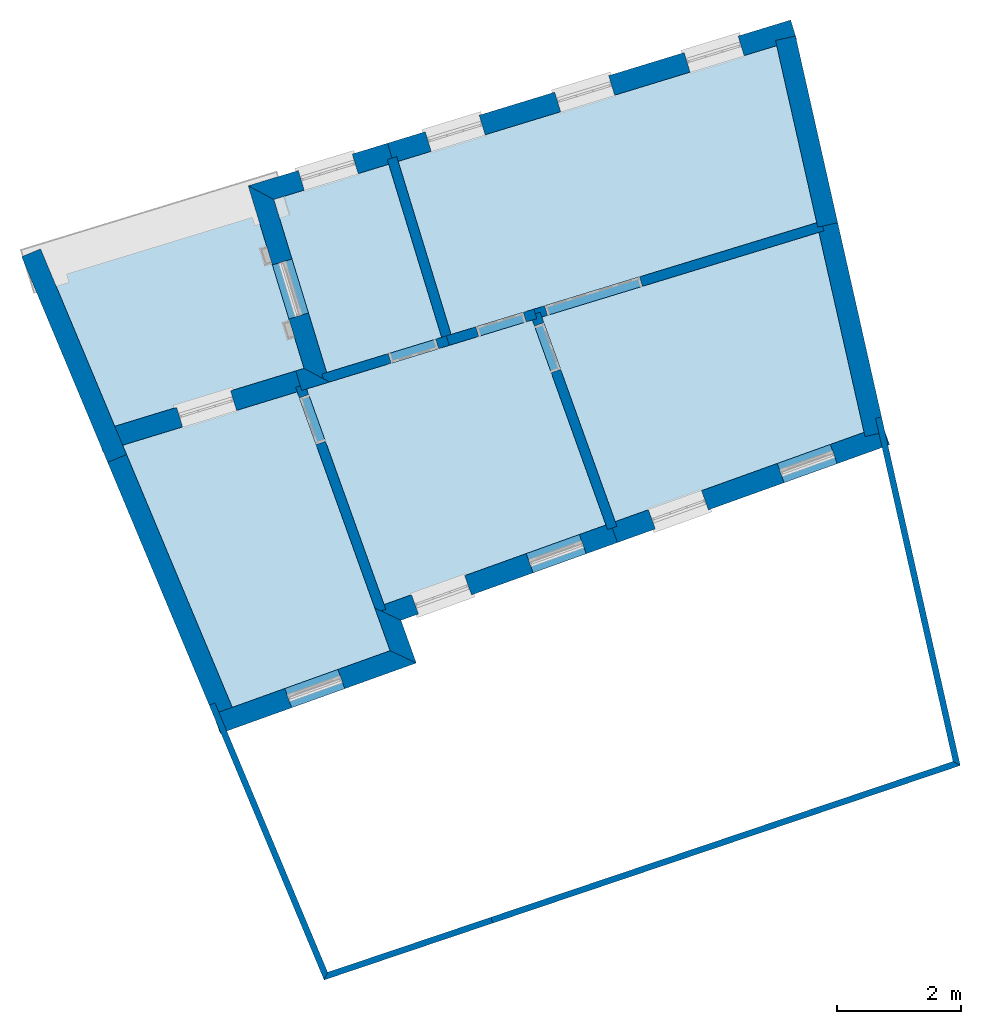
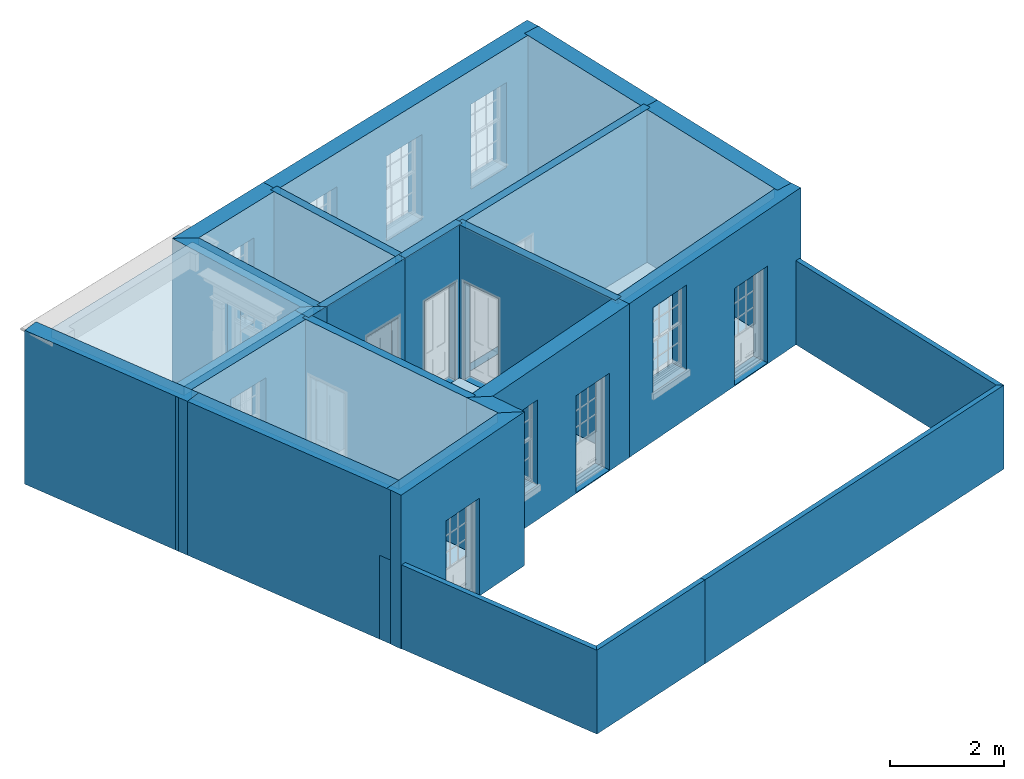
# One storey, part 1 of 10: 23 walls, 10 slabs, 16 openings.
"""IFC2X3 building model written with IfcOpenShell, lengths in metres."""

from ifc_helpers import new_model, si_unit, frame, origin, place, context, subcontext, project, spatial, polyline, outline, extrude, material, layer, layer_set, layer_usage, element, save


model = new_model("IFC2X3")

# Units and contexts
model_context = context("Model", 3, world=origin())
body_context = subcontext(model_context, "Body", "Model", "MODEL_VIEW")
ifc_project = project(units=[si_unit("PLANEANGLEUNIT", "RADIAN"), si_unit("MASSUNIT", "GRAM", prefix="KILO"), si_unit("FORCEUNIT", "NEWTON", prefix="KILO"), si_unit("LENGTHUNIT", "METRE")], contexts=[model_context])

# Site, building, storey
site_placement = place(None, origin())
site = spatial("IfcSite", under=ifc_project, at=site_placement, CompositionType="ELEMENT")
building_placement = place(None, origin())
building = spatial("IfcBuilding", under=site, at=building_placement, Name="Building plot-9", CompositionType="ELEMENT")
storey_placement = place(None, frame((0.0, 0.0, 1.0)))
storey = spatial("IfcBuildingStorey", under=building, at=storey_placement, Name="Floor 0", CompositionType="ELEMENT", Elevation=1.0)

# Slabs
slab_1_placement = place(storey_placement, frame((0.0, 0.0, 3.1)))
element("IfcSlab", 1, at=slab_1_placement, inside=storey, Name="Slab", ObjectType="Slab", PredefinedType="FLOOR", context=body_context, shape_type="SweptSolid", body=[
    extrude(outline(polyline([(40.8949943241668, 20.7638038113086), (40.2503249563729, 23.6181688571686), (34.146951060941, 21.7523270051611), (35.0000685345139, 18.9616859267981), (40.8949943241668, 20.7638038113086)])), origin(), (0.0, 0.0, 1.0), 0.2),
])
slab_2_placement = place(storey_placement, frame((0.0, 0.0, 3.1)))
element("IfcSlab", 2, at=slab_2_placement, inside=storey, Name="Slab", ObjectType="Slab", PredefinedType="FLOOR", context=body_context, shape_type="SweptSolid", body=[
    extrude(outline(polyline([(29.6423853775052, 17.323806675844), (32.840715311725, 18.301557334748), (31.9875978381522, 21.0921984131111), (28.5108407742954, 20.0293307353073), (29.6423853775052, 17.323806675844)])), origin(), (0.0, 0.0, 1.0), 0.2),
])
slab_3_placement = place(storey_placement, frame((0.0, 0.0, 3.1)))
element("IfcSlab", 3, at=slab_3_placement, inside=storey, Name="Slab", ObjectType="Slab", PredefinedType="FLOOR", context=body_context, shape_type="SweptSolid", body=[
    extrude(outline(polyline([(32.9937251016799, 18.3483334416613), (34.847058744559, 18.9149098198848), (33.9939412709861, 21.7055508982478), (32.1406076281071, 21.1389745200244), (32.9937251016799, 18.3483334416613)])), origin(), (0.0, 0.0, 1.0), 0.2),
])
slab_4_placement = place(storey_placement, frame((0.0, 0.0, 3.1)))
element("IfcSlab", 4, at=slab_4_placement, inside=storey, Name="Slab", ObjectType="Slab", PredefinedType="FLOOR", context=body_context, shape_type="SweptSolid", body=[
    extrude(outline(polyline([(40.9303413006452, 20.6073000604293), (36.4626012366867, 19.2414823114195), (37.6464003453221, 15.9436830568112), (41.6583709221279, 17.3838456701231), (40.9303413006452, 20.6073000604293)])), origin(), (0.0, 0.0, 1.0), 0.2),
])
slab_5_placement = place(storey_placement, frame((0.0, 0.0, 3.1)))
element("IfcSlab", 5, at=slab_5_placement, inside=storey, Name="Slab", ObjectType="Slab", PredefinedType="FLOOR", context=body_context, shape_type="SweptSolid", body=[
    extrude(outline(polyline([(32.5183923728544, 18.0357115201682), (29.7044275381413, 17.1754638196932), (31.4719804769569, 12.9492433165192), (34.0163978591737, 13.8626036506437), (32.5183923728544, 18.0357115201682)])), origin(), (0.0, 0.0, 1.0), 0.2),
])
slab_6_placement = place(storey_placement, origin())
element("IfcSlab", 6, at=slab_6_placement, inside=storey, Name="Slab", ObjectType="Slab", PredefinedType="FLOOR", context=body_context, shape_type="SweptSolid", body=[
    extrude(outline(polyline([(36.3094153316108, 19.1946523649464), (32.6715782779303, 18.0825414666413), (33.9195826432877, 14.605880742874), (37.4958088166108, 15.8896257586881), (36.3094153316108, 19.1946523649464)])), origin(), (0.0, 0.0, 1.0), 0.02),
])
slab_7_placement = place(storey_placement, origin())
element("IfcSlab", 7, at=slab_7_placement, inside=storey, Name="Slab", ObjectType="Slab", PredefinedType="FLOOR", context=body_context, shape_type="SweptSolid", body=[
    extrude(outline(polyline([(32.9937251016799, 18.3483334416613), (34.847058744559, 18.9149098198848), (33.9939412709861, 21.7055508982478), (32.1406076281071, 21.1389745200244), (32.9937251016799, 18.3483334416613)])), origin(), (0.0, 0.0, 1.0), 0.02),
])
slab_8_placement = place(storey_placement, origin())
element("IfcSlab", 8, at=slab_8_placement, inside=storey, Name="Slab", ObjectType="Slab", PredefinedType="FLOOR", context=body_context, shape_type="SweptSolid", body=[
    extrude(outline(polyline([(40.9303413006452, 20.6073000604293), (36.4626012366867, 19.2414823114195), (37.6464003453221, 15.9436830568112), (41.6583709221279, 17.3838456701231), (40.9303413006452, 20.6073000604293)])), origin(), (0.0, 0.0, 1.0), 0.02),
])
slab_9_placement = place(storey_placement, origin())
element("IfcSlab", 9, at=slab_9_placement, inside=storey, Name="Slab", ObjectType="Slab", PredefinedType="FLOOR", context=body_context, shape_type="SweptSolid", body=[
    extrude(outline(polyline([(40.8949943241668, 20.7638038113086), (40.2503249563729, 23.6181688571686), (34.146951060941, 21.7523270051611), (35.0000685345139, 18.9616859267981), (40.8949943241668, 20.7638038113086)])), origin(), (0.0, 0.0, 1.0), 0.02),
])
slab_10_placement = place(storey_placement, origin())
element("IfcSlab", 10, at=slab_10_placement, inside=storey, Name="Slab", ObjectType="Slab", PredefinedType="FLOOR", context=body_context, shape_type="SweptSolid", body=[
    extrude(outline(polyline([(32.5183923728544, 18.0357115201682), (29.7044275381413, 17.1754638196932), (31.4719804769569, 12.9492433165192), (34.0163978591737, 13.8626036506437), (32.5183923728544, 18.0357115201682)])), origin(), (0.0, 0.0, 1.0), 0.02),
])

# Wall, opening
ifc_material_1 = material(Name="Masonry")
ifc_layer_1 = layer(ifc_material_1, 0.33, ventilated=False)
ifc_layer_set_1 = layer_set([ifc_layer_1], Name="My Wall")
ifc_layer_usage_1 = layer_usage(ifc_layer_set_1, "AXIS2", "NEGATIVE", 0.08)
wall_1_placement = place(storey_placement, origin())
wall_1 = element("IfcWallStandardCase", 11, at=wall_1_placement, inside=storey, material=ifc_layer_usage_1, Name="exterior", context=body_context, shape_type="SweptSolid", body=[
    extrude(outline(polyline([(31.1651656744123, 12.8391071130311), (31.2766588517913, 12.5285120850639), (34.4384860645198, 13.6635018000555), (34.0163978591737, 13.8626036506437), (31.1651656744123, 12.8391071130311)])), origin(), (0.0, 0.0, 1.0), 3.3),
])
opening_1_placement = place(storey_placement, frame((0.0, 0.0, 0.02)))
element("IfcOpeningElement", 12, at=opening_1_placement, cuts=wall_1, Name="Opening", ObjectType="Opening", context=body_context, shape_type="SweptSolid", body=[
    extrude(outline(polyline([(32.4293277983826, 12.9422815010221), (33.2858171179285, 13.2497323840973), (33.1743239405496, 13.5603274120645), (32.3178346210036, 13.2528765289893), (32.4293277983826, 12.9422815010221)])), origin(), (0.0, 0.0, 1.0), 2.08),
])

# Wall
wall_2_placement = place(storey_placement, origin())
element("IfcWallStandardCase", 13, at=wall_2_placement, inside=storey, material=ifc_layer_usage_1, Name="exterior", context=body_context, shape_type="SweptSolid", body=[
    extrude(outline(polyline([(34.0163978591737, 13.8626036506437), (34.4384860645198, 13.6635018000555), (34.1910793199225, 14.3527215941627), (33.7689911145764, 14.5518234447509), (34.0163978591737, 13.8626036506437)])), origin(), (0.0, 0.0, 1.0), 3.3),
])

# Wall, openings
wall_3_placement = place(storey_placement, origin())
wall_3 = element("IfcWallStandardCase", 14, at=wall_3_placement, inside=storey, material=ifc_layer_usage_1, Name="exterior", context=body_context, shape_type="SweptSolid", body=[
    extrude(outline(polyline([(33.7689911145764, 14.5518234447509), (34.1910793199225, 14.3527215941627), (37.6825977583454, 15.6060593797825), (37.5711045809664, 15.9166544077497), (33.7689911145764, 14.5518234447509)])), origin(), (0.0, 0.0, 1.0), 3.3),
])
opening_2_placement = place(storey_placement, frame((0.0, 0.0, 0.75)))
element("IfcOpeningElement", 15, at=opening_2_placement, cuts=wall_3, Name="Opening", ObjectType="Opening", context=body_context, shape_type="SweptSolid", body=[
    extrude(outline(polyline([(34.4734384362563, 14.4540790281435), (35.3299277558022, 14.7615299112188), (35.2184345784233, 15.072124939186), (34.3619452588774, 14.7646740561107), (34.4734384362563, 14.4540790281435)])), origin(), (0.0, 0.0, 1.0), 1.82),
])
opening_3_placement = place(storey_placement, frame((0.0, 0.0, 0.02)))
element("IfcOpeningElement", 16, at=opening_3_placement, cuts=wall_3, Name="Opening", ObjectType="Opening", context=body_context, shape_type="SweptSolid", body=[
    extrude(outline(polyline([(36.3226486730638, 15.1178833597605), (37.1791379926097, 15.4253342428358), (37.0676448152308, 15.735929270803), (36.2111554956849, 15.4284783877277), (36.3226486730638, 15.1178833597605)])), origin(), (0.0, 0.0, 1.0), 2.08),
])

wall_4_placement = place(storey_placement, origin())
wall_4 = element("IfcWallStandardCase", 17, at=wall_4_placement, inside=storey, material=ifc_layer_usage_1, Name="exterior", context=body_context, shape_type="SweptSolid", body=[
    extrude(outline(polyline([(37.5711045809664, 15.9166544077497), (37.6825977583454, 15.6060593797825), (42.071756598514, 17.1816199040899), (41.9602634211351, 17.4922149320571), (37.5711045809664, 15.9166544077497)])), origin(), (0.0, 0.0, 1.0), 3.3),
])
opening_4_placement = place(storey_placement, frame((0.0, 0.0, 1.05)))
element("IfcOpeningElement", 18, at=opening_4_placement, cuts=wall_4, Name="Opening", ObjectType="Opening", context=body_context, shape_type="SweptSolid", body=[
    extrude(outline(polyline([(38.2928179927117, 15.8251079372423), (39.1493073122576, 16.1325588203176), (39.0378141348787, 16.4431538482848), (38.1813248153328, 16.1357029652096), (38.2928179927117, 15.8251079372423)])), origin(), (0.0, 0.0, 1.0), 1.82),
])
opening_5_placement = place(storey_placement, frame((0.0, 0.0, 0.02)))
element("IfcOpeningElement", 19, at=opening_5_placement, cuts=wall_4, Name="Opening", ObjectType="Opening", context=body_context, shape_type="SweptSolid", body=[
    extrude(outline(polyline([(40.3697477809902, 16.5706559352374), (41.2262371005362, 16.8781068183126), (41.1147439231572, 17.1887018462798), (40.2582546036113, 16.8812509632046), (40.3697477809902, 16.5706559352374)])), origin(), (0.0, 0.0, 1.0), 2.08),
])

wall_5_placement = place(storey_placement, origin())
wall_5 = element("IfcWallStandardCase", 20, at=wall_5_placement, inside=storey, material=ifc_layer_usage_1, Name="exterior", context=body_context, shape_type="SweptSolid", body=[
    extrude(outline(polyline([(40.5718353424252, 23.7164567131035), (40.4753596219165, 24.0320394048854), (33.9739704454548, 22.0445216434864), (34.0704461659636, 21.7289389517045), (40.5718353424252, 23.7164567131035)])), origin(), (0.0, 0.0, 1.0), 3.3),
])
opening_6_placement = place(storey_placement, frame((0.0, 0.0, 0.75)))
element("IfcOpeningElement", 21, at=opening_6_placement, cuts=wall_5, Name="Opening", ObjectType="Opening", context=body_context, shape_type="SweptSolid", body=[
    extrude(outline(polyline([(39.62768485202, 23.772899609477), (38.7574416716517, 23.5068605014075), (38.8539173921604, 23.1912778096256), (39.7241605725287, 23.457316917695), (39.62768485202, 23.772899609477)])), origin(), (0.0, 0.0, 1.0), 1.82),
])
opening_7_placement = place(storey_placement, frame((0.0, 0.0, 0.75)))
element("IfcOpeningElement", 22, at=opening_7_placement, cuts=wall_5, Name="Opening", ObjectType="Opening", context=body_context, shape_type="SweptSolid", body=[
    extrude(outline(polyline([(37.5402477254676, 23.1347562446946), (36.6700045450993, 22.8687171366251), (36.766480265608, 22.5531344448432), (37.6367234459763, 22.8191735529127), (37.5402477254676, 23.1347562446946)])), origin(), (0.0, 0.0, 1.0), 1.82),
])
opening_8_placement = place(storey_placement, frame((0.0, 0.0, 0.75)))
element("IfcOpeningElement", 23, at=opening_8_placement, cuts=wall_5, Name="Opening", ObjectType="Opening", context=body_context, shape_type="SweptSolid", body=[
    extrude(outline(polyline([(35.4528105989152, 22.4966128799123), (34.5825674185469, 22.2305737718428), (34.6790431390556, 21.9149910800609), (35.5492863194239, 22.1810301881304), (35.4528105989152, 22.4966128799123)])), origin(), (0.0, 0.0, 1.0), 1.82),
])

# Wall, opening
wall_6_placement = place(storey_placement, origin())
wall_6 = element("IfcWallStandardCase", 24, at=wall_6_placement, inside=storey, material=ifc_layer_usage_1, Name="exterior", context=body_context, shape_type="SweptSolid", body=[
    extrude(outline(polyline([(34.0704461659636, 21.7289389517045), (33.9739704454548, 22.0445216434864), (31.7285492158165, 21.3580814912976), (32.1406076281071, 21.1389745200244), (34.0704461659636, 21.7289389517045)])), origin(), (0.0, 0.0, 1.0), 3.3),
])
opening_9_placement = place(storey_placement, frame((0.0, 0.0, 0.75)))
element("IfcOpeningElement", 25, at=opening_9_placement, cuts=wall_6, Name="Opening", ObjectType="Opening", context=body_context, shape_type="SweptSolid", body=[
    extrude(outline(polyline([(33.4059203192221, 21.8708649549528), (32.5356771388537, 21.6048258468833), (32.6321528593624, 21.2892431551014), (33.5023960397308, 21.5552822631709), (33.4059203192221, 21.8708649549528)])), origin(), (0.0, 0.0, 1.0), 1.82),
])

wall_7_placement = place(storey_placement, origin())
wall_7 = element("IfcWallStandardCase", 26, at=wall_7_placement, inside=storey, material=ifc_layer_usage_1, Name="exterior", context=body_context, shape_type="SweptSolid", body=[
    extrude(outline(polyline([(32.1406076281071, 21.1389745200244), (31.7285492158165, 21.3580814912976), (32.6284427963026, 18.4144306229796), (33.0405012085932, 18.1953236517064), (32.1406076281071, 21.1389745200244)])), origin(), (0.0, 0.0, 1.0), 3.3),
])
opening_10_placement = place(storey_placement, frame((0.0, 0.0, 0.02)))
element("IfcOpeningElement", 27, at=opening_10_placement, cuts=wall_7, Name="Opening", ObjectType="Opening", context=body_context, shape_type="SweptSolid", body=[
    extrude(outline(polyline([(32.1185641190768, 20.0822998505183), (32.3846032271463, 19.21205667015), (32.7001859189282, 19.3085323906587), (32.4341468108587, 20.178775571027), (32.1185641190768, 20.0822998505183)])), origin(), (0.0, 0.0, 1.0), 2.545),
])

# Wall
wall_8_placement = place(storey_placement, origin())
element("IfcWallStandardCase", 28, at=wall_8_placement, inside=storey, material=ifc_layer_usage_1, Name="exterior", context=body_context, shape_type="SweptSolid", body=[
    extrude(outline(polyline([(33.0405012085932, 18.1953236517064), (32.6284427963026, 18.4144306229796), (32.494837899153, 18.3735867204094), (32.5913136196618, 18.0580040286275), (33.0405012085932, 18.1953236517064)])), origin(), (0.0, 0.0, 1.0), 3.3),
])

# Wall, opening
wall_9_placement = place(storey_placement, origin())
wall_9 = element("IfcWallStandardCase", 29, at=wall_9_placement, inside=storey, material=ifc_layer_usage_1, Name="exterior", context=body_context, shape_type="SweptSolid", body=[
    extrude(outline(polyline([(32.5913136196618, 18.0580040286275), (32.494837899153, 18.3735867204094), (29.2843562617075, 17.3921212052898), (29.3808319822162, 17.0765385135079), (32.5913136196618, 18.0580040286275)])), origin(), (0.0, 0.0, 1.0), 3.3),
])
opening_11_placement = place(storey_placement, frame((0.0, 0.0, 0.75)))
element("IfcOpeningElement", 30, at=opening_11_placement, cuts=wall_9, Name="Opening", ObjectType="Opening", context=body_context, shape_type="SweptSolid", body=[
    extrude(outline(polyline([(31.4442575690167, 18.0524173504104), (30.5740143886483, 17.7863782423409), (30.670490109157, 17.470795550559), (31.5407332895254, 17.7368346586285), (31.4442575690167, 18.0524173504104)])), origin(), (0.0, 0.0, 1.0), 1.82),
])

# Walls
wall_10_placement = place(storey_placement, origin())
element("IfcWallStandardCase", 31, at=wall_10_placement, inside=storey, material=ifc_layer_usage_1, Name="party", context=body_context, shape_type="SweptSolid", body=[
    extrude(outline(polyline([(41.6739583213653, 17.3148302495654), (41.995850572897, 17.3875308575671), (41.2332436027483, 20.7640813624728), (40.9113513512166, 20.6913807544711), (41.6739583213653, 17.3148302495654)])), origin(), (0.0, 0.0, 1.0), 3.3),
])
wall_11_placement = place(storey_placement, origin())
element("IfcWallStandardCase", 32, at=wall_11_placement, inside=storey, material=ifc_layer_usage_1, Name="party", context=body_context, shape_type="SweptSolid", body=[
    extrude(outline(polyline([(40.9113513512166, 20.6913807544711), (41.2332436027483, 20.7640813624728), (40.553227258476, 23.774950159212), (40.2313350069443, 23.7022495512103), (40.9113513512166, 20.6913807544711)])), origin(), (0.0, 0.0, 1.0), 3.3),
])
wall_12_placement = place(storey_placement, origin())
element("IfcWallStandardCase", 33, at=wall_12_placement, inside=storey, material=ifc_layer_usage_1, Name="party", context=body_context, shape_type="SweptSolid", body=[
    extrude(outline(polyline([(29.6703267210227, 17.2569989009441), (29.3658811147555, 17.1296691211414), (31.1968529762769, 12.7518139225968), (31.5012985825441, 12.8791437023995), (29.6703267210227, 17.2569989009441)])), origin(), (0.0, 0.0, 1.0), 3.3),
])

# Wall, opening
ifc_material_2 = material(Name="Masonry")
ifc_layer_2 = layer(ifc_material_2, 0.16, ventilated=False)
ifc_layer_set_2 = layer_set([ifc_layer_2], Name="My Wall")
ifc_layer_usage_2 = layer_usage(ifc_layer_set_2, "AXIS2", "NEGATIVE", 0.08)
wall_13_placement = place(storey_placement, origin())
wall_13 = element("IfcWallStandardCase", 34, at=wall_13_placement, inside=storey, material=ifc_layer_usage_2, Name="interior", context=body_context, shape_type="SweptSolid", body=[
    extrude(outline(polyline([(33.7960197636379, 14.4765276803952), (33.9466112923493, 14.5305849785184), (32.6432213305608, 18.1615375726665), (32.4926298018494, 18.1074802745433), (33.7960197636379, 14.4765276803952)])), origin(), (0.0, 0.0, 1.0), 3.3),
])
opening_12_placement = place(storey_placement, frame((0.0, 0.0, 0.02)))
element("IfcOpeningElement", 35, at=opening_12_placement, cuts=wall_13, Name="Opening", ObjectType="Opening", context=body_context, shape_type="SweptSolid", body=[
    extrude(outline(polyline([(32.9743222815649, 17.2391644593093), (32.7040357909493, 17.9921221028662), (32.5534442622379, 17.938064804743), (32.8237307528535, 17.1851071611862), (32.9743222815649, 17.2391644593093)])), origin(), (0.0, 0.0, 1.0), 2.1),
])

wall_14_placement = place(storey_placement, origin())
wall_14 = element("IfcWallStandardCase", 36, at=wall_14_placement, inside=storey, material=ifc_layer_usage_2, Name="interior", context=body_context, shape_type="SweptSolid", body=[
    extrude(outline(polyline([(34.9703397464498, 18.7852880833866), (34.9235636395364, 18.9382978733414), (32.9172202067024, 18.3249453882046), (32.9639963136158, 18.1719355982498), (34.9703397464498, 18.7852880833866)])), origin(), (0.0, 0.0, 1.0), 3.3),
])
opening_13_placement = place(storey_placement, frame((0.0, 0.0, 0.02)))
element("IfcOpeningElement", 37, at=opening_13_placement, cuts=wall_14, Name="Opening", ObjectType="Opening", context=body_context, shape_type="SweptSolid", body=[
    extrude(outline(polyline([(34.7514276258372, 18.885674753064), (33.9863786760629, 18.6517942184974), (34.0331547829762, 18.4987844285425), (34.7982037327505, 18.7326649631091), (34.7514276258372, 18.885674753064)])), origin(), (0.0, 0.0, 1.0), 2.1),
])

wall_15_placement = place(storey_placement, origin())
wall_15 = element("IfcWallStandardCase", 38, at=wall_15_placement, inside=storey, material=ifc_layer_usage_2, Name="interior", context=body_context, shape_type="SweptSolid", body=[
    extrude(outline(polyline([(36.3355604715048, 19.3699546633605), (36.3823365784182, 19.2169448734057), (41.0127738898931, 20.6325002493123), (40.9659977829797, 20.7855100392671), (36.3355604715048, 19.3699546633605)])), origin(), (0.0, 0.0, 1.0), 3.3),
])
opening_14_placement = place(storey_placement, frame((0.0, 0.0, 0.02)))
element("IfcOpeningElement", 39, at=opening_14_placement, cuts=wall_15, Name="Opening", ObjectType="Opening", context=body_context, shape_type="SweptSolid", body=[
    extrude(outline(polyline([(36.5544725921174, 19.2695679936831), (38.0845704916661, 19.7373290628163), (38.0377943847528, 19.8903388527712), (36.5076964852041, 19.422577783638), (36.5544725921174, 19.2695679936831)])), origin(), (0.0, 0.0, 1.0), 2.1),
])

wall_16_placement = place(storey_placement, origin())
wall_16 = element("IfcWallStandardCase", 40, at=wall_16_placement, inside=storey, material=ifc_layer_usage_2, Name="interior", context=body_context, shape_type="SweptSolid", body=[
    extrude(outline(polyline([(34.9235636395364, 18.9382978733414), (34.9703397464498, 18.7852880833866), (36.3823365784182, 19.2169448734057), (36.3355604715048, 19.3699546633605), (34.9235636395364, 18.9382978733414)])), origin(), (0.0, 0.0, 1.0), 3.3),
])
opening_15_placement = place(storey_placement, frame((0.0, 0.0, 0.02)))
element("IfcOpeningElement", 41, at=opening_15_placement, cuts=wall_16, Name="Opening", ObjectType="Opening", context=body_context, shape_type="SweptSolid", body=[
    extrude(outline(polyline([(35.4451516149446, 18.9304412185616), (36.2102005647189, 19.1643217531282), (36.1634244578056, 19.3173315430831), (35.3983755080313, 19.0834510085165), (35.4451516149446, 18.9304412185616)])), origin(), (0.0, 0.0, 1.0), 2.1),
])

wall_17_placement = place(storey_placement, origin())
wall_17 = element("IfcWallStandardCase", 42, at=wall_17_placement, inside=storey, material=ifc_layer_usage_2, Name="interior", context=body_context, shape_type="SweptSolid", body=[
    extrude(outline(polyline([(36.4342442893172, 19.3204784174447), (36.2836527606058, 19.2664211193215), (37.5228374656723, 15.8143299943324), (37.6734289943837, 15.8683872924556), (36.4342442893172, 19.3204784174447)])), origin(), (0.0, 0.0, 1.0), 3.3),
])
opening_16_placement = place(storey_placement, frame((0.0, 0.0, 0.02)))
element("IfcOpeningElement", 43, at=opening_16_placement, cuts=wall_17, Name="Opening", ObjectType="Opening", context=body_context, shape_type="SweptSolid", body=[
    extrude(outline(polyline([(36.3444672209943, 19.0970056495212), (36.6147537116099, 18.3440480059644), (36.7653452403213, 18.3981053040875), (36.4950587497057, 19.1510629476444), (36.3444672209943, 19.0970056495212)])), origin(), (0.0, 0.0, 1.0), 2.1),
])

# Walls
wall_18_placement = place(storey_placement, origin())
element("IfcWallStandardCase", 44, at=wall_18_placement, inside=storey, material=ifc_layer_usage_2, Name="interior", context=body_context, shape_type="SweptSolid", body=[
    extrude(outline(polyline([(34.1235630074843, 21.8288319001386), (33.9705532175295, 21.7820557932252), (34.8704467980157, 18.8384049249073), (35.0234565879705, 18.8851810318207), (34.1235630074843, 21.8288319001386)])), origin(), (0.0, 0.0, 1.0), 3.3),
])
wall_19_placement = place(storey_placement, origin())
element("IfcWallStandardCase", 45, at=wall_19_placement, inside=storey, material=ifc_layer_usage_1, Name="party", context=body_context, shape_type="SweptSolid", body=[
    extrude(outline(polyline([(28.3802780027808, 20.3415064273667), (28.0758323965136, 20.2141766475639), (29.4623430691516, 16.8990285103329), (29.7667886754187, 17.0263582901357), (28.3802780027808, 20.3415064273667)])), origin(), (0.0, 0.0, 1.0), 3.3),
])
ifc_material_3 = material(Name="Masonry")
ifc_layer_3 = layer(ifc_material_3, 0.1, ventilated=False)
ifc_layer_set_3 = layer_set([ifc_layer_3], Name="My Wall")
ifc_layer_usage_3 = layer_usage(ifc_layer_set_3, "AXIS2", "NEGATIVE", -0.15)
wall_20_placement = place(storey_placement, origin())
element("IfcWallStandardCase", 46, at=wall_20_placement, inside=storey, material=ifc_layer_usage_3, Name="fence", context=body_context, shape_type="SweptSolid", body=[
    extrude(outline(polyline([(31.1926472662043, 13.0210393151636), (31.1003910218809, 12.9824545334052), (32.9530410281361, 8.55276687330758), (33.0093576198208, 8.67728339352924), (31.1926472662043, 13.0210393151636)])), origin(), (0.0, 0.0, 1.0), 1.8),
])
wall_21_placement = place(storey_placement, origin())
element("IfcWallStandardCase", 47, at=wall_21_placement, inside=storey, material=ifc_layer_usage_3, Name="fence", context=body_context, shape_type="SweptSolid", body=[
    extrude(outline(polyline([(33.0093576198208, 8.67728339352924), (32.9530410281361, 8.55276687330758), (35.6730947258306, 9.4697963431589), (35.6411477832474, 9.56455600155627), (33.0093576198208, 8.67728339352924)])), origin(), (0.0, 0.0, 1.0), 1.8),
])
wall_22_placement = place(storey_placement, origin())
element("IfcWallStandardCase", 48, at=wall_22_placement, inside=storey, material=ifc_layer_usage_3, Name="fence", context=body_context, shape_type="SweptSolid", body=[
    extrude(outline(polyline([(35.6411477832474, 9.56455600155627), (35.6730947258306, 9.4697963431589), (43.2101993050039, 12.0108296405205), (43.0927863796354, 12.0767755938979), (35.6411477832474, 9.56455600155627)])), origin(), (0.0, 0.0, 1.0), 1.8),
])
wall_23_placement = place(storey_placement, origin())
element("IfcWallStandardCase", 49, at=wall_23_placement, inside=storey, material=ifc_layer_usage_3, Name="fence", context=body_context, shape_type="SweptSolid", body=[
    extrude(outline(polyline([(43.0927863796354, 12.0767755938979), (43.2101993050039, 12.0108296405205), (41.940774354714, 17.631388623879), (41.8432312481892, 17.6093581366058), (43.0927863796354, 12.0767755938979)])), origin(), (0.0, 0.0, 1.0), 1.8),
])

save(model, "model.ifc")
